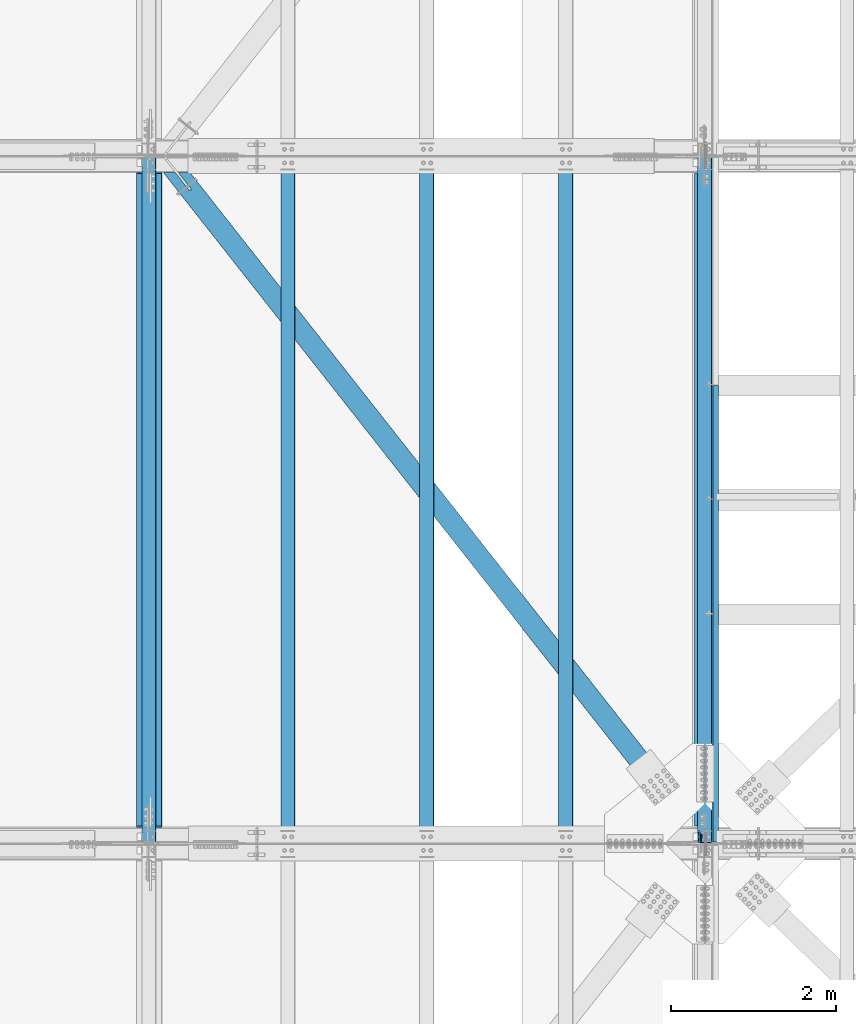
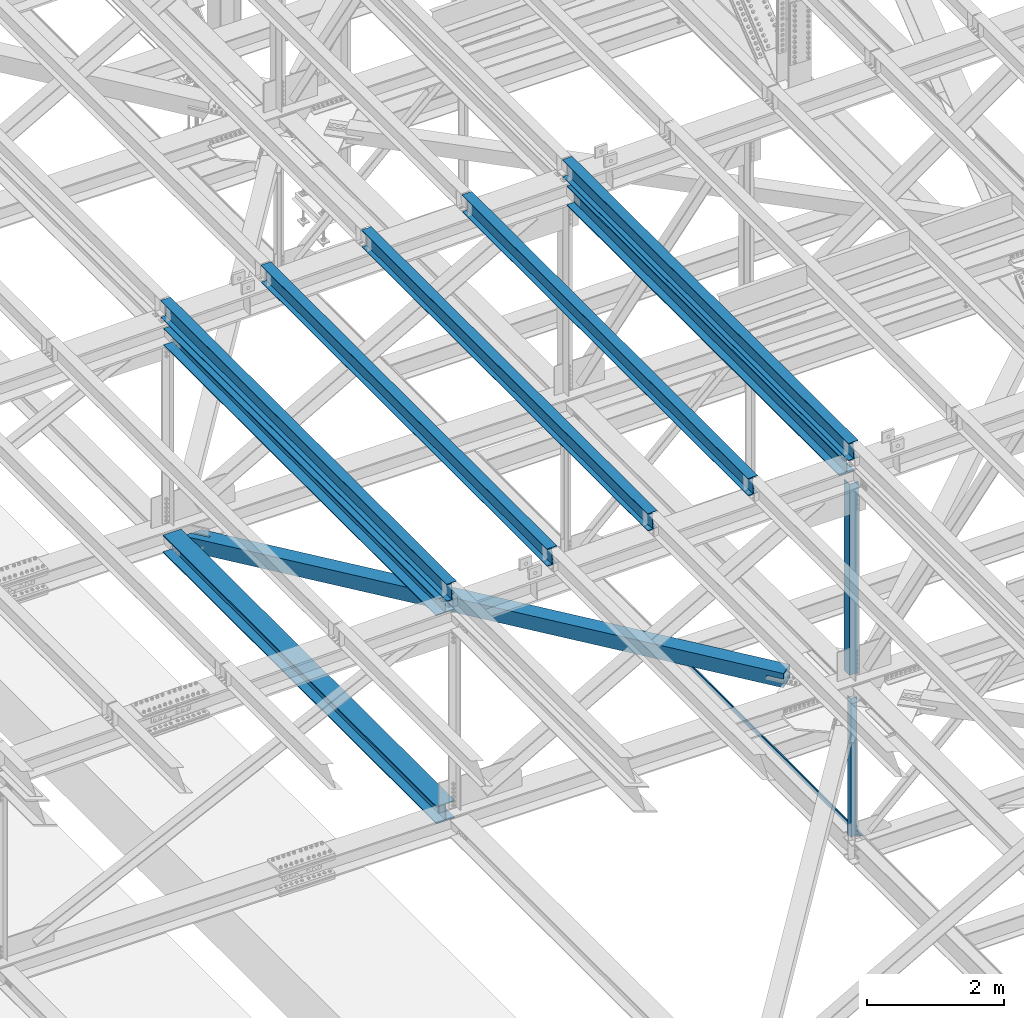
# One storey, part 1862 of 3843: 12 beams, 12 elements without a shape of their own.
"""IFC2X3 building model written with IfcOpenShell, lengths in millimetres."""

from ifc_helpers import new_model, si_unit, frame, origin_with_axes, place, context, subcontext, project, spatial, faceted_brep, material, type_object, element, aggregate, save


model = new_model("IFC2X3")

# Units and contexts
model_context = context("Model", 3, precision=1e-05, world=origin_with_axes())
body_context = subcontext(model_context, "Body", "Model", "MODEL_VIEW")
ifc_project = project(units=[si_unit("LENGTHUNIT", "METRE", prefix="MILLI"), si_unit("AREAUNIT", "SQUARE_METRE"), si_unit("VOLUMEUNIT", "CUBIC_METRE"), si_unit("MASSUNIT", "GRAM", prefix="KILO"), si_unit("TIMEUNIT", "SECOND"), si_unit("PLANEANGLEUNIT", "RADIAN"), si_unit("SOLIDANGLEUNIT", "STERADIAN"), si_unit("THERMODYNAMICTEMPERATUREUNIT", "DEGREE_CELSIUS"), si_unit("LUMINOUSINTENSITYUNIT", "LUMEN")], contexts=[model_context])

# Site, building, storey
site_placement = place(None, origin_with_axes())
site = spatial("IfcSite", under=ifc_project, at=site_placement, CompositionType="ELEMENT")
building_placement = place(site_placement, origin_with_axes())
building = spatial("IfcBuilding", under=site, at=building_placement, Name="Undefined", CompositionType="ELEMENT")
storey_placement = place(building_placement, origin_with_axes())
storey = spatial("IfcBuildingStorey", under=building, at=storey_placement, Name="Undefined", CompositionType="ELEMENT", Elevation=0.0)

# Assembly, beam
assembly_1_placement = place(storey_placement, origin_with_axes())
assembly_1 = element("IfcElementAssembly", 1, at=assembly_1_placement, inside=storey, Name="ANGLE", AssemblyPlace="NOTDEFINED", PredefinedType="RIGID_FRAME")
ifc_material_1 = material(Name="STEEL/A572-50")
beam_type_1 = type_object("IfcBeamType", Name="L4X4X3/8", PredefinedType="NOTDEFINED")
beam_1_placement = place(assembly_1_placement, frame((77012.8000000275, 58975.625, 42373.9661655574), z_axis=(0.0, 1.0, 0.0), x_axis=(0.0, 0.0, -1.0)))
beam_1 = element("IfcBeam", 2, at=beam_1_placement, type_object=beam_type_1, material=ifc_material_1, Name="ANGLE", ObjectType="L4X4X3/8", context=body_context, shape_type="Brep", body=[
    faceted_brep([(241.012372567442, 50.8000000000029, -50.8000000000029), (241.012372567442, 50.8000000000029, 50.8000000000029), (2707.317716577, 50.8000000000029, 50.8000000000029), (2707.317716577, 50.8000000000029, -50.8000000000029), (241.012372567442, 41.2749999999942, 50.8000000000029), (2707.317716577, 41.2749999999942, 50.8000000000029), (241.012372567442, 41.2749999999942, -41.2750000000015), (2707.317716577, 41.2749999999942, -41.2750000000015), (241.012372567442, -50.8000000000029, -41.2750000000015), (2707.317716577, -50.8000000000029, -41.2750000000015), (241.012372567442, -50.8000000000029, -50.8000000000029), (2707.317716577, -50.8000000000029, -50.8000000000029)], [[[0, 1, 2, 3]], [[1, 4, 5, 2]], [[4, 6, 7, 5]], [[6, 8, 9, 7]], [[8, 10, 11, 9]], [[10, 0, 3, 11]], [[5, 7, 9, 11, 3, 2]], [[10, 8, 6, 4, 1, 0]]]),
])
aggregate(assembly_1, [beam_1])

assembly_2_placement = place(storey_placement, origin_with_axes())
assembly_2 = element("IfcElementAssembly", 3, at=assembly_2_placement, inside=storey, Name="BEAM", AssemblyPlace="NOTDEFINED", PredefinedType="RIGID_FRAME")
ifc_material_2 = material(Name="STEEL/A992")
beam_type_2 = type_object("IfcBeamType", Name="W12X26", PredefinedType="NOTDEFINED")
beam_2_placement = place(assembly_2_placement, frame((77009.5092623529, 58915.3906758699, 46525.4301644783), z_axis=(-0.0211520976064639, 0.000583214000143924, 0.999776099248365), x_axis=(0.0, 0.999999830070643, -0.000582974000041111)))
beam_2 = element("IfcBeam", 4, at=beam_2_placement, type_object=beam_type_2, material=ifc_material_2, Name="BEAM", ObjectType="W12X26", context=body_context, shape_type="Brep", body=[
    faceted_brep([(12.7010201108424, 82.5500000006723, -155.575000000368), (12.6954685248857, 82.5500000006577, -146.05000000033), (8343.89688422998, 82.5500000000466, -146.049999972034), (8343.90243581592, 82.5500000000611, -155.574999972065), (12.694489742018, 3.17500000022119, -146.050000000447), (8343.89590544711, 3.17499999961001, -146.049999972136), (12.5242411061263, 3.17499999981374, 146.050000000541), (8343.72565681121, 3.17499999920256, 146.050000028845), (12.5252198890012, 82.5500000002648, 146.050000000658), (8343.7266355941, 82.5499999996537, 146.050000028954), (12.5196683030445, 82.5500000002503, 155.575000000688), (8343.72108400814, 82.5499999996246, 155.575000028985), (12.5176324346758, -82.5500000006869, 155.575000000455), (8343.71904813976, -82.550000001298, 155.575000028759), (12.5231840206252, -82.5500000006723, 146.050000000425), (8343.72459972571, -82.5500000012835, 146.050000028721), (12.5241628035001, -3.17500000023574, 146.050000000534), (8343.72557850859, -3.17500000084692, 146.050000028838), (12.6944114393918, -3.17499999981374, -146.050000000454), (8343.89582714447, -3.17500000042492, -146.049999972151), (12.693432656517, -82.5500000002648, -146.050000000563), (8343.8948483616, -82.550000000876, -146.049999972267), (12.6989842424664, -82.5500000002503, -155.575000000594), (8343.90039994755, -82.5500000008615, -155.574999972298)], [[[0, 1, 2, 3]], [[1, 4, 5, 2]], [[4, 6, 7, 5]], [[6, 8, 9, 7]], [[8, 10, 11, 9]], [[10, 12, 13, 11]], [[12, 14, 15, 13]], [[14, 16, 17, 15]], [[16, 18, 19, 17]], [[18, 20, 21, 19]], [[20, 22, 23, 21]], [[22, 0, 3, 23]], [[5, 7, 9, 11, 13, 15, 17, 19, 21, 23, 3, 2]], [[22, 20, 18, 16, 14, 12, 10, 8, 6, 4, 1, 0]]]),
])
aggregate(assembly_2, [beam_2])

assembly_3_placement = place(storey_placement, origin_with_axes())
assembly_3 = element("IfcElementAssembly", 5, at=assembly_3_placement, inside=storey, Name="BEAM", AssemblyPlace="NOTDEFINED", PredefinedType="RIGID_FRAME")
beam_3_placement = place(assembly_3_placement, frame((70253.109262364, 58915.3755799217, 46388.1141315793), z_axis=(-0.0211520985042007, 0.00048581000014383, 0.999776151304637), x_axis=(0.0, 0.999999881941356, -0.000485918999971274)))
beam_3 = element("IfcBeam", 6, at=beam_3_placement, type_object=beam_type_2, material=ifc_material_2, Name="BEAM", ObjectType="W12X26", context=body_context, shape_type="Brep", body=[
    faceted_brep([(12.7008499790682, 82.5500000002212, -155.575000000274), (12.6962226355317, 82.5500000002357, -146.050000000272), (8343.89720618844, 82.5500000004395, -146.050000010691), (8343.90183353197, 82.5500000004395, -155.575000010693), (12.6954068028572, 3.17499999978463, -146.050000000032), (8343.89639035576, 3.17500000000291, -146.050000010444), (12.5535016011563, 3.17500000026484, 146.049999999981), (8343.75448515406, 3.17500000048312, 146.049999989562), (12.5543174338382, 82.550000000716, 146.049999999734), (8343.75530098674, 82.5500000009342, 146.049999989315), (12.5496900903017, 82.550000000716, 155.574999999735), (8343.75067364321, 82.5500000009342, 155.574999989323), (12.5479931583395, -82.5500000002066, 155.575000000237), (8343.74897671123, -82.5499999999884, 155.574999989825), (12.5526205018687, -82.5500000002212, 146.050000000243), (8343.75360405477, -82.5500000000029, 146.049999989824), (12.5534363345505, -3.17499999978463, 146.049999999996), (8343.75441988745, -3.17499999956635, 146.049999989584), (12.6953415362368, -3.17500000026484, -146.05000000001), (8343.89632508915, -3.17500000004657, -146.050000010422), (12.6945257035622, -82.550000000716, -146.04999999977), (8343.89550925647, -82.5500000004977, -146.050000010182), (12.6991530470914, -82.550000000716, -155.574999999764), (8343.9001366, -82.5500000004977, -155.575000010191)], [[[0, 1, 2, 3]], [[1, 4, 5, 2]], [[4, 6, 7, 5]], [[6, 8, 9, 7]], [[8, 10, 11, 9]], [[10, 12, 13, 11]], [[12, 14, 15, 13]], [[14, 16, 17, 15]], [[16, 18, 19, 17]], [[18, 20, 21, 19]], [[20, 22, 23, 21]], [[22, 0, 3, 23]], [[5, 7, 9, 11, 13, 15, 17, 19, 21, 23, 3, 2]], [[22, 20, 18, 16, 14, 12, 10, 8, 6, 4, 1, 0]]]),
])
aggregate(assembly_3, [beam_3])

assembly_4_placement = place(storey_placement, origin_with_axes())
assembly_4 = element("IfcElementAssembly", 7, at=assembly_4_placement, inside=storey, Name="BEAM", AssemblyPlace="NOTDEFINED", PredefinedType="RIGID_FRAME")
beam_4_placement = place(assembly_4_placement, frame((75320.4092623738, 58915.3861721807, 46491.9559762283), z_axis=(-0.0211520982414222, 0.000553894999946352, 0.999776115908114), x_axis=(2.20000002032105e-08, 0.999999846532016, -0.000554017999740348)))
beam_4 = element("IfcBeam", 8, at=beam_4_placement, type_object=beam_type_2, material=ifc_material_2, Name="BEAM", ObjectType="W12X26", context=body_context, shape_type="Brep", body=[
    faceted_brep([(12.7009674660585, 82.5500000010798, -155.574999999371), (12.6956916199779, 82.5500000010215, -146.049999999399), (8343.89697025072, 82.5499999801395, -146.04999999443), (8343.90224609679, 82.5499999801978, -155.574999994402), (12.6947631985749, 3.17500000059954, -146.049999999486), (8343.89604182932, 3.17499997971754, -146.049999994524), (12.5329705854965, 3.17499999934807, 146.049999999515), (8343.73424921622, 3.17499997845152, 146.050000004478), (12.5338990069067, 82.5499999997846, 146.049999999603), (8343.73517763764, 82.5499999788735, 146.050000004565), (12.5286231608261, 82.5499999997264, 155.574999999568), (8343.72990179156, 82.5499999788299, 155.575000004537), (12.5266920443028, -82.5500000011671, 155.574999999393), (8343.72797067503, -82.5500000220636, 155.575000004363), (12.5319678903834, -82.5500000011234, 146.049999999421), (8343.73324652111, -82.55000002202, 146.05000000439), (12.5328963117863, -3.1750000007014, 146.049999999508), (8343.73417494253, -3.1750000215834, 146.050000004478), (12.6946889248647, -3.17499999942083, -146.049999999494), (8343.89596755559, -3.17500002033194, -146.049999994524), (12.6937605034545, -82.5499999998574, -146.049999999581), (8343.89500687108, -82.5499999800086, -146.050000023337), (12.6990363495352, -82.5499999998283, -155.574999999553), (8343.90031498027, -82.5500000207103, -155.574999994577)], [[[0, 1, 2, 3]], [[1, 4, 5, 2]], [[4, 6, 7, 5]], [[6, 8, 9, 7]], [[8, 10, 11, 9]], [[10, 12, 13, 11]], [[12, 14, 15, 13]], [[14, 16, 17, 15]], [[16, 18, 19, 17]], [[18, 20, 21, 19]], [[20, 22, 23, 21]], [[22, 0, 3, 23]], [[5, 7, 9, 11, 13, 15, 17, 19, 21, 23, 3, 2]], [[22, 20, 18, 16, 14, 12, 10, 8, 6, 4, 1, 0]]]),
])
aggregate(assembly_4, [beam_4])

assembly_5_placement = place(storey_placement, origin_with_axes())
assembly_5 = element("IfcElementAssembly", 9, at=assembly_5_placement, inside=storey, Name="BEAM", AssemblyPlace="NOTDEFINED", PredefinedType="RIGID_FRAME")
beam_5_placement = place(assembly_5_placement, frame((73631.3092623095, 58915.3831280496, 46457.9307083186), z_axis=(-0.0211520980283531, 0.000534327999768721, 0.999776126561636), x_axis=(0.0, 0.999999857183192, -0.000534447000097718)))
beam_5 = element("IfcBeam", 10, at=beam_5_placement, type_object=beam_type_2, material=ifc_material_2, Name="BEAM", ObjectType="W12X26", context=body_context, shape_type="Brep", body=[
    faceted_brep([(12.7009674660585, 82.5500000010798, -155.574999999371), (12.6958454841952, 82.5499999999738, -146.049999999654), (8343.89703527035, 82.5499999994936, -146.049999976647), (8343.90212473978, 82.549999999479, -155.574999976649), (12.6949481756164, 3.1749999995809, -146.049999999894), (8343.89613796179, 3.17499999910069, -146.049999976894), (12.5388711134801, 3.17500000046857, 146.049999999974), (8343.74006089966, 3.17499999997381, 146.050000022973), (12.5397684220588, 82.550000000876, 146.050000000214), (8343.74095820825, 82.5500000003958, 146.050000023213), (12.5346789526448, 82.5500000009051, 155.575000000208), (8343.73586873883, 82.5500000004249, 155.575000023207), (12.5328125508022, -82.5499999999738, 155.574999999706), (8343.73400233698, -82.550000000454, 155.575000022713), (12.5379020202163, -82.5499999999884, 146.049999999719), (8343.7390918064, -82.5500000004686, 146.050000022711), (12.538799328795, -3.1749999995809, 146.049999999952), (8343.73998911498, -3.17500000006112, 146.050000022951), (12.6948763909313, -3.17500000045402, -146.049999999908), (8343.89606617711, -3.17500000094878, -146.049999976916), (12.6939790823453, -82.550000000876, -146.050000000156), (8343.89516152057, -82.5499999634485, -146.049999970179), (12.6990363495352, -82.5499999998283, -155.574999999553), (8343.90025833794, -82.5500000013853, -155.574999977143)], [[[0, 1, 2, 3]], [[1, 4, 5, 2]], [[4, 6, 7, 5]], [[6, 8, 9, 7]], [[8, 10, 11, 9]], [[10, 12, 13, 11]], [[12, 14, 15, 13]], [[14, 16, 17, 15]], [[16, 18, 19, 17]], [[18, 20, 21, 19]], [[20, 22, 23, 21]], [[22, 0, 3, 23]], [[5, 7, 9, 11, 13, 15, 17, 19, 21, 23, 3, 2]], [[22, 20, 18, 16, 14, 12, 10, 8, 6, 4, 1, 0]]]),
])
aggregate(assembly_5, [beam_5])

assembly_6_placement = place(storey_placement, origin_with_axes())
assembly_6 = element("IfcElementAssembly", 11, at=assembly_6_placement, inside=storey, Name="BEAM", AssemblyPlace="NOTDEFINED", PredefinedType="RIGID_FRAME")
beam_6_placement = place(assembly_6_placement, frame((71942.2092623211, 58915.3782587312, 46423.2842819306), z_axis=(-0.0211520976735046, 0.000503028999904926, 0.999776142806896), x_axis=(2.20000007948506e-08, 0.999999873424559, -0.000503141000213845)))
beam_6 = element("IfcBeam", 12, at=beam_6_placement, type_object=beam_type_2, material=ifc_material_2, Name="BEAM", ObjectType="W12X26", context=body_context, shape_type="Brep", body=[
    faceted_brep([(12.7008499790682, 82.5500000002212, -155.575000000274), (12.69608696879, 82.5500000007305, -146.050000000432), (8343.89714154231, 82.549999980547, -146.050000030053), (8343.90193289321, 82.5499999805761, -155.575000030076), (12.6952439670349, 3.1750000002794, -146.050000000345), (8343.89629854056, 3.17499998012499, -146.050000029958), (12.5483092059367, 3.17499999969732, 146.050000000236), (8343.74936377945, 3.17499997952837, 146.049999970608), (12.5491522076845, 82.5500000001193, 146.050000000141), (8343.75020678121, 82.5499999799504, 146.049999970521), (12.5443608567803, 82.5500000001048, 155.575000000164), (8343.74541543029, 82.5499999799504, 155.574999970537), (12.5426074131392, -82.5500000007887, 155.575000000361), (8343.74366198666, -82.5500000209577, 155.574999970733), (12.5473987640435, -82.5500000007742, 146.05000000033), (8343.74845333756, -82.5500000209431, 146.049999970703), (12.5482417657986, -3.1750000003376, 146.050000000236), (8343.74929633931, -3.17500002050656, 146.049999970623), (12.6951765269041, -3.17499999974098, -146.050000000338), (8343.89623110041, -3.17500001990993, -146.050000029958), (12.694333525149, -82.5500000001775, -146.050000000243), (8343.89538809867, -82.5500000203465, -146.050000029863), (12.6991530470914, -82.550000000716, -155.574999999764), (8343.9001366, -82.5500000004977, -155.575000010191)], [[[0, 1, 2, 3]], [[1, 4, 5, 2]], [[4, 6, 7, 5]], [[6, 8, 9, 7]], [[8, 10, 11, 9]], [[10, 12, 13, 11]], [[12, 14, 15, 13]], [[14, 16, 17, 15]], [[16, 18, 19, 17]], [[18, 20, 21, 19]], [[20, 22, 23, 21]], [[22, 0, 3, 23]], [[5, 7, 9, 11, 13, 15, 17, 19, 21, 23, 3, 2]], [[22, 20, 18, 16, 14, 12, 10, 8, 6, 4, 1, 0]]]),
])
aggregate(assembly_6, [beam_6])

assembly_7_placement = place(storey_placement, origin_with_axes())
assembly_7 = element("IfcElementAssembly", 13, at=assembly_7_placement, inside=storey, Name="BENT_PLATE", AssemblyPlace="NOTDEFINED", PredefinedType="RIGID_FRAME")
ifc_material_3 = material(Name="STEEL/A36")
beam_type_3 = type_object("IfcBeamType", PredefinedType="NOTDEFINED")
beam_7_placement = place(assembly_7_placement, frame((77179.4875000007, 61710.09375, 39627.1749999995), z_axis=(0.0, 1.0, 0.0), x_axis=(-1.0, 0.0, 0.0)))
beam_7 = element("IfcBeam", 14, at=beam_7_placement, type_object=beam_type_3, material=ifc_material_3, Name="BENT_PLATE", context=body_context, shape_type="Brep", body=[
    faceted_brep([(0.0, -3.17500000000291, -2776.53750000001), (0.0, -3.17500000000291, 2776.53750000001), (0.0, 3.17500000000291, 2776.53750000001), (0.0, 3.17500000000291, -2776.53750000001), (69.8500000010827, 3.17500000000291, 2776.53750000001), (69.8500000010827, 3.17500000000291, -2776.53750000001), (76.2000000010739, -3.17500000000291, -2776.53750000001), (76.2000000010739, -3.17500000000291, 2776.53750000001), (69.8500000011554, 73.0249999989392, 2776.53750000001), (69.8500000011554, 73.0249999989392, -2776.53750000001), (76.2000000011612, 73.0249999989246, 2776.53750000001), (76.2000000011612, 73.0249999989246, -2776.53750000001)], [[[0, 1, 2, 3]], [[3, 2, 4, 5]], [[1, 0, 6, 7]], [[5, 4, 8, 9]], [[4, 2, 1, 7, 10, 8]], [[7, 6, 11, 10]], [[6, 0, 3, 5, 9, 11]], [[10, 11, 9, 8]]]),
])
aggregate(assembly_7, [beam_7])

assembly_8_placement = place(storey_placement, origin_with_axes())
assembly_8 = element("IfcElementAssembly", 15, at=assembly_8_placement, inside=storey, Name="BEAM", AssemblyPlace="NOTDEFINED", PredefinedType="RIGID_FRAME")
beam_type_4 = type_object("IfcBeamType", Name="W12X79", PredefinedType="NOTDEFINED")
beam_8_placement = place(assembly_8_placement, frame((70256.4, 58915.3, 42348.1653744154), z_axis=(0.0, 0.000478400999789301, 0.999999885566235), x_axis=(9.99999573346044e-10, 0.999999885566235, -0.000478400999792905)))
beam_8 = element("IfcBeam", 16, at=beam_8_placement, type_object=beam_type_4, material=ifc_material_2, Name="BEAM", ObjectType="W12X79", context=body_context, shape_type="Brep", body=[
    faceted_brep([(198.512709257586, 153.987499999188, -157.162499999889), (198.503595717499, 153.987499999188, -138.112499999937), (8158.22950352775, 153.987499966694, -138.112500014337), (8158.23861706784, 153.987499966694, -157.162500014289), (198.503595866212, 6.34999999919091, -138.112500000003), (8158.22950367647, 6.34999996669649, -138.112500014402), (198.37144953492, 6.34999999919091, 138.112499999304), (8158.09735734518, 6.34999996669649, 138.112499984905), (198.371449386206, 153.987499999188, 138.11249999937), (8158.09735719646, 153.987499966694, 138.112499984971), (198.362335846119, 153.987499999203, 157.162499999329), (8158.08824365637, 153.987499966708, 157.16249998493), (198.362336156337, -153.987500000803, 157.162499999184), (8158.08824396659, -153.987500033298, 157.162499984785), (198.371449696424, -153.987500000803, 138.112499999224), (8158.09735750667, -153.987500033312, 138.112499984825), (198.371449547711, -6.35000000080618, 138.112499999297), (8158.09735735795, -6.3500000333006, 138.112499984898), (198.503595879003, -6.35000000080618, -138.11250000001), (8158.22950368926, -6.3500000333006, -138.112500014409), (198.503596027716, -153.987500000818, -138.112500000083), (8158.22950383797, -153.987500033312, -138.112500014482), (198.512709567804, -153.987500000803, -157.162500000035), (8158.23861737807, -153.987500033298, -157.162500014434)], [[[0, 1, 2, 3]], [[1, 4, 5, 2]], [[4, 6, 7, 5]], [[6, 8, 9, 7]], [[8, 10, 11, 9]], [[10, 12, 13, 11]], [[12, 14, 15, 13]], [[14, 16, 17, 15]], [[16, 18, 19, 17]], [[18, 20, 21, 19]], [[20, 22, 23, 21]], [[22, 0, 3, 23]], [[5, 7, 9, 11, 13, 15, 17, 19, 21, 23, 3, 2]], [[22, 20, 18, 16, 14, 12, 10, 8, 6, 4, 1, 0]]]),
])
aggregate(assembly_8, [beam_8])

assembly_9_placement = place(storey_placement, origin_with_axes())
assembly_9 = element("IfcElementAssembly", 17, at=assembly_9_placement, inside=storey, Name="ANGLE", AssemblyPlace="NOTDEFINED", PredefinedType="RIGID_FRAME")
beam_type_5 = type_object("IfcBeamType", Name="L6X6X1/2", PredefinedType="NOTDEFINED")
beam_9_placement = place(assembly_9_placement, frame((77012.7999988756, 59001.025, 46173.0019409753), z_axis=(0.0, 1.0, 0.0), x_axis=(0.0, 0.0, -1.0)))
beam_9 = element("IfcBeam", 18, at=beam_9_placement, type_object=beam_type_5, material=ifc_material_1, Name="ANGLE", ObjectType="L6X6X1/2", context=body_context, shape_type="Brep", body=[
    faceted_brep([(224.11680196457, 76.1999999990803, -76.1999999999971), (224.11680196457, 76.1999999990803, 76.1999999999971), (3620.0624217531, 76.1999999852269, 76.1999999999971), (3620.0624217531, 76.1999999852269, -76.1999999999971), (224.116801977354, 63.4999999990832, 76.1999999999971), (3620.06242176588, 63.4999999852298, 76.1999999999971), (224.116801977354, 63.4999999990832, -63.5), (3620.06242176588, 63.4999999852298, -63.5), (224.116802118078, -76.2000000009139, -63.5), (3620.06242190661, -76.2000000147818, -63.5), (224.116802118078, -76.2000000009139, -76.1999999999971), (3620.06242190661, -76.2000000147818, -76.1999999999971)], [[[0, 1, 2, 3]], [[1, 4, 5, 2]], [[4, 6, 7, 5]], [[6, 8, 9, 7]], [[8, 10, 11, 9]], [[10, 0, 3, 11]], [[5, 7, 9, 11, 3, 2]], [[10, 8, 6, 4, 1, 0]]]),
])
aggregate(assembly_9, [beam_9])

assembly_10_placement = place(storey_placement, origin_with_axes())
assembly_10 = element("IfcElementAssembly", 19, at=assembly_10_placement, inside=storey, AssemblyPlace="NOTDEFINED", PredefinedType="RIGID_FRAME")
ifc_material_4 = material()
beam_type_6 = type_object("IfcBeamType", Name="HSS10X10X3/4", PredefinedType="NOTDEFINED")
beam_10_placement = place(assembly_10_placement, frame((70434.2, 67271.9, 42246.55), z_axis=(0.785737876999385, 0.618559607999504, 0.0), x_axis=(0.618559605792669, -0.78573787873668, 0.0)))
beam_10 = element("IfcBeam", 20, at=beam_10_placement, type_object=beam_type_6, material=ifc_material_4, ObjectType="HSS10X10X3/4", context=body_context, shape_type="Brep", body=[
    faceted_brep([(9326.24878472707, -26.9869995121189, -127.000000040338), (9326.24879747884, -26.9869995121189, -107.950000040451), (9578.6613695448, -26.9869995121189, -107.950000041572), (9578.6613695448, -26.9869995121189, -127.000000041458), (9320.78119504125, -25.8994283038337, -127.000000040309), (9320.78120779301, -25.8994283038337, -107.950000040437), (9316.14599632126, -22.8022875365932, -127.000000040294), (9316.14600907302, -22.8022875365932, -107.950000040408), (9313.04885555405, -18.1670888165463, -127.00000004028), (9313.04886830582, -18.1670888165463, -107.950000040393), (9311.96128434578, -12.6994991306492, -127.00000004028), (9311.96129709755, -12.6994991306492, -107.950000040393), (9313.04885555405, -7.23191020769445, -127.00000004028), (9313.04886830582, -7.23191020769445, -107.950000040393), (9316.14599632126, -2.59671148764755, -127.000000040294), (9316.14600907302, -2.59671148764755, -107.950000040408), (9320.78119504125, 0.500429279592936, -127.000000040309), (9320.78120779301, 0.500429279592936, -107.950000040437), (9326.24878472707, 1.58800048787816, -127.000000040338), (9326.24879747884, 1.58800048787816, -107.950000040451), (9578.6613695448, 1.58800048787816, -127.000000041458), (9578.6613695448, 1.58800048787816, -107.950000041572), (9578.6613695448, -107.949999999997, -107.950000041572), (9578.6613695448, 107.949999999997, -107.950000041572), (167.56732370008, 107.949999999997, -107.950000000565), (167.56732370008, -107.949999999997, -107.950000000565), (516.209344809561, 107.949999999997, 14.2875004909001), (516.209344809561, 127.0, 14.2875004909001), (521.676934495421, 127.0, 13.1999292826367), (521.676934495421, 107.949999999997, 13.1999292826367), (526.312133215446, 127.0, 10.1027885154035), (526.312133215446, 107.949999999997, 10.1027885154035), (529.409273982694, 127.0, 5.46758979538572), (529.409273982694, 107.949999999997, 5.46758979538572), (530.496845191009, 127.0, 1.09503162093461e-07), (530.496845191009, 107.949999999997, 1.09503162093461e-07), (529.40927398276, 127.0, -5.4675888120546), (529.40927398276, 107.949999999997, -5.4675888120546), (526.312133215585, 127.0, -10.1027875320869), (526.312133215585, 107.949999999997, -10.1027875320869), (521.676934495611, 127.0, -13.1999282993202), (521.676934495611, 107.949999999997, -13.1999282993202), (516.209344809772, 127.0, -14.2874995075981), (516.209344809772, 107.949999999997, -14.2874995075981), (241.301632587426, 127.0, -14.2874995080638), (241.301632587426, 107.949999999997, -14.2874995080638), (516.209344809561, -127.0, 14.2875004909001), (516.209344809561, -107.949999999997, 14.2875004909001), (521.676934495421, -107.949999999997, 13.1999292826367), (521.676934495421, -127.0, 13.1999292826367), (526.312133215446, -107.949999999997, 10.1027885154035), (526.312133215446, -127.0, 10.1027885154035), (529.409273982694, -107.949999999997, 5.46758979538572), (529.409273982694, -127.0, 5.46758979538572), (530.496845191009, -107.949999999997, 1.09503162093461e-07), (530.496845191009, -127.0, 1.09503162093461e-07), (529.40927398276, -107.949999999997, -5.4675888120546), (529.40927398276, -127.0, -5.4675888120546), (526.312133215585, -107.949999999997, -10.1027875320869), (526.312133215585, -127.0, -10.1027875320869), (521.676934495611, -107.949999999997, -13.1999282993202), (521.676934495611, -127.0, -13.1999282993202), (516.209344809772, -107.949999999997, -14.2874995075981), (516.209344809772, -127.0, -14.2874995075981), (241.301632587426, -107.949999999997, -14.2874995080638), (241.301632587426, -127.0, -14.2874995080638), (152.570515191763, 127.0, -127.000000000466), (152.570515191763, -127.0, -127.000000000466), (9578.6613695448, 127.0, -127.000000041458), (9578.6613695448, -127.0, -127.000000041458), (9578.66136954481, 107.949999999997, 107.949999957098), (9578.66136954481, 127.0, 126.999999956999), (9578.66136954481, 1.58800048787816, 126.999999956999), (9578.66136954481, 1.58800048787816, 107.949999957098), (9326.24895475062, 1.58800048787816, 126.999999958105), (9326.24894199887, 1.58800048787816, 107.949999958204), (9320.7813650648, 0.500429279592936, 126.999999958134), (9320.78135231303, 0.500429279592936, 107.949999958233), (9316.1461663448, -2.59671148764755, 126.999999958134), (9316.14615359304, -2.59671148764755, 107.949999958262), (9313.04902557761, -7.23191020769445, 126.999999958163), (9313.04901282584, -7.23191020769445, 107.949999958291), (9311.96145436934, -12.6994991306492, 126.999999958163), (9311.96144161756, -12.6994991306492, 107.949999958277), (9313.04902557761, -18.1670888165463, 126.999999958163), (9313.04901282584, -18.1670888165463, 107.949999958291), (9316.1461663448, -22.8022875365932, 126.999999958134), (9316.14615359304, -22.8022875365932, 107.949999958262), (9320.7813650648, -25.8994283038337, 126.999999958134), (9320.78135231303, -25.8994283038337, 107.949999958233), (9326.24895475062, -26.9869995121189, 126.999999958105), (9326.24894199887, -26.9869995121189, 107.949999958204), (9578.66136954481, -26.9869995121189, 126.999999956999), (9578.66136954481, -26.9869995121189, 107.949999957098), (9578.66136954481, -107.949999999997, 107.949999957098), (9578.66136954481, -127.0, 126.999999956999), (352.527961969396, -127.0, 126.999999998239), (263.796845348849, -127.0, 14.2875004904345), (263.796845348849, -107.949999999997, 14.2875004904345), (337.531153461072, -107.949999999997, 107.949999998338), (337.531153461072, 107.949999999997, 107.949999998338), (263.796845348849, 107.949999999997, 14.2875004904345), (263.796845348849, 127.0, 14.2875004904345), (352.527961969396, 127.0, 126.999999998239)], [[[0, 1, 2, 3]], [[1, 0, 4, 5]], [[5, 4, 6, 7]], [[7, 6, 8, 9]], [[9, 8, 10, 11]], [[11, 10, 12, 13]], [[13, 12, 14, 15]], [[15, 14, 16, 17]], [[17, 16, 18, 19]], [[19, 18, 20, 21]], [[22, 2, 1, 5, 7, 9, 11, 13, 15, 17, 19, 21, 23, 24, 25]], [[26, 27, 28, 29]], [[29, 28, 30, 31]], [[31, 30, 32, 33]], [[33, 32, 34, 35]], [[35, 34, 36, 37]], [[37, 36, 38, 39]], [[39, 38, 40, 41]], [[41, 40, 42, 43]], [[43, 42, 44, 45]], [[46, 47, 48, 49]], [[49, 48, 50, 51]], [[51, 50, 52, 53]], [[53, 52, 54, 55]], [[55, 54, 56, 57]], [[57, 56, 58, 59]], [[59, 58, 60, 61]], [[61, 60, 62, 63]], [[63, 62, 64, 65]], [[25, 24, 45, 44, 66, 67, 65, 64]], [[68, 20, 18, 16, 14, 12, 10, 8, 6, 4, 0, 3, 69, 67, 66]], [[70, 23, 21, 20, 68, 71, 72, 73]], [[74, 75, 73, 72]], [[76, 77, 75, 74]], [[78, 79, 77, 76]], [[80, 81, 79, 78]], [[82, 83, 81, 80]], [[84, 85, 83, 82]], [[86, 87, 85, 84]], [[88, 89, 87, 86]], [[90, 91, 89, 88]], [[91, 90, 92, 93]], [[3, 2, 22, 94, 93, 92, 95, 69]], [[46, 49, 51, 53, 55, 57, 59, 61, 63, 65, 67, 69, 95, 96, 97]], [[47, 46, 97, 98]], [[94, 22, 25, 64, 62, 60, 58, 56, 54, 52, 50, 48, 47, 98, 99]], [[70, 73, 75, 77, 79, 81, 83, 85, 87, 89, 91, 93, 94, 99, 100]], [[26, 29, 31, 33, 35, 37, 39, 41, 43, 45, 24, 23, 70, 100, 101]], [[27, 26, 101, 102]], [[71, 68, 66, 44, 42, 40, 38, 36, 34, 32, 30, 28, 27, 102, 103]], [[95, 92, 90, 88, 86, 84, 82, 80, 78, 76, 74, 72, 71, 103, 96]], [[102, 101, 100, 99, 98, 97, 96, 103]]]),
])
aggregate(assembly_10, [beam_10])

assembly_11_placement = place(storey_placement, origin_with_axes())
assembly_11 = element("IfcElementAssembly", 21, at=assembly_11_placement, inside=storey, Name="BEAM", AssemblyPlace="NOTDEFINED", PredefinedType="RIGID_FRAME")
beam_type_7 = type_object("IfcBeamType", Name="W14X68", PredefinedType="NOTDEFINED")
beam_11_placement = place(assembly_11_placement, frame((77012.8, 58915.300000001, 46173.0024029817), z_axis=(0.0, 0.000582974000040849, 0.999999830070643), x_axis=(0.0, 0.999999830070643, -0.000582974000041111)))
beam_11 = element("IfcBeam", 22, at=beam_11_placement, type_object=beam_type_7, material=ifc_material_2, Name="BEAM", ObjectType="W14X68", context=body_context, shape_type="Brep", body=[
    faceted_brep([(212.828688941772, 127.0, -177.799999999166), (212.817583285185, 127.0, -158.749999999178), (8143.96893101054, 127.0, -158.749999972228), (8143.98003666712, 127.0, -177.799999972209), (212.817583285185, 5.55624999999418, -158.749999999178), (8143.96893101054, 5.55624999999418, -158.749999972228), (212.63248900872, 5.55624999999418, 158.750000000618), (8143.78383673405, 5.55624999999418, 158.750000027569), (212.63248900872, 127.0, 158.750000000618), (8143.78383673405, 127.0, 158.750000027569), (212.621383352132, 127.0, 177.800000000607), (8143.77273107747, 127.0, 177.800000027557), (212.621383352132, -127.0, 177.800000000607), (8143.77273107747, -127.0, 177.800000027557), (212.63248900872, -127.0, 158.750000000618), (8143.78383673405, -127.0, 158.750000027569), (212.63248900872, -5.55624999999418, 158.750000000618), (8143.78383673405, -5.55624999999418, 158.750000027569), (212.817583285185, -5.55624999999418, -158.749999999178), (8143.96893101054, -5.55624999999418, -158.749999972228), (212.817583285185, -127.0, -158.749999999178), (8143.96893101054, -127.0, -158.749999972228), (212.828688941772, -127.0, -177.799999999166), (8143.98003666712, -127.0, -177.799999972209)], [[[0, 1, 2, 3]], [[1, 4, 5, 2]], [[4, 6, 7, 5]], [[6, 8, 9, 7]], [[8, 10, 11, 9]], [[10, 12, 13, 11]], [[12, 14, 15, 13]], [[14, 16, 17, 15]], [[16, 18, 19, 17]], [[18, 20, 21, 19]], [[20, 22, 23, 21]], [[22, 0, 3, 23]], [[5, 7, 9, 11, 13, 15, 17, 19, 21, 23, 3, 2]], [[22, 20, 18, 16, 14, 12, 10, 8, 6, 4, 1, 0]]]),
])
aggregate(assembly_11, [beam_11])

assembly_12_placement = place(storey_placement, origin_with_axes())
assembly_12 = element("IfcElementAssembly", 23, at=assembly_12_placement, inside=storey, Name="BEAM", AssemblyPlace="NOTDEFINED", PredefinedType="RIGID_FRAME")
beam_type_8 = type_object("IfcBeamType", Name="W12X65", PredefinedType="NOTDEFINED")
beam_12_placement = place(assembly_12_placement, frame((70256.4, 58915.3000000006, 46035.681285543), z_axis=(0.0, 0.000485918999969725, 0.999999881941356), x_axis=(0.0, 0.999999881941356, -0.000485918999971274)))
beam_12 = element("IfcBeam", 24, at=beam_12_placement, type_object=beam_type_8, material=ifc_material_2, Name="BEAM", ObjectType="W12X65", context=body_context, shape_type="Brep", body=[
    faceted_brep([(212.799850573843, 152.399999999994, -153.98750000009), (212.792136608812, 152.399999999994, -138.112500000112), (8143.94307293318, 152.399999999994, -138.112500010029), (8143.95078689822, 152.399999999994, -153.987500010007), (212.792136608812, 4.76249999999709, -138.112500000112), (8143.94307293318, 4.76249999999709, -138.112500010029), (212.657913617186, 4.76249999999709, 138.112499999603), (8143.80884994156, 4.76249999999709, 138.112499989678), (212.657913617186, 152.399999999994, 138.112499999603), (8143.80884994156, 152.399999999994, 138.112499989678), (212.650199652155, 152.399999999994, 153.987499999581), (8143.80113597654, 152.399999999994, 153.987499989664), (212.650199652155, -152.399999999994, 153.987499999581), (8143.80113597654, -152.399999999994, 153.987499989664), (212.657913617186, -152.399999999994, 138.112499999603), (8143.80884994156, -152.399999999994, 138.112499989678), (212.657913617186, -4.76249999999709, 138.112499999603), (8143.80884994156, -4.76249999999709, 138.112499989678), (212.792136608812, -4.76249999999709, -138.112500000112), (8143.94307293318, -4.76249999999709, -138.112500010029), (212.792136608812, -152.399999999994, -138.112500000112), (8143.94307293318, -152.399999999994, -138.112500010029), (212.799850573843, -152.399999999994, -153.98750000009), (8143.95078689822, -152.399999999994, -153.987500010007)], [[[0, 1, 2, 3]], [[1, 4, 5, 2]], [[4, 6, 7, 5]], [[6, 8, 9, 7]], [[8, 10, 11, 9]], [[10, 12, 13, 11]], [[12, 14, 15, 13]], [[14, 16, 17, 15]], [[16, 18, 19, 17]], [[18, 20, 21, 19]], [[20, 22, 23, 21]], [[22, 0, 3, 23]], [[5, 7, 9, 11, 13, 15, 17, 19, 21, 23, 3, 2]], [[22, 20, 18, 16, 14, 12, 10, 8, 6, 4, 1, 0]]]),
])
aggregate(assembly_12, [beam_12])

save(model, "model.ifc")
